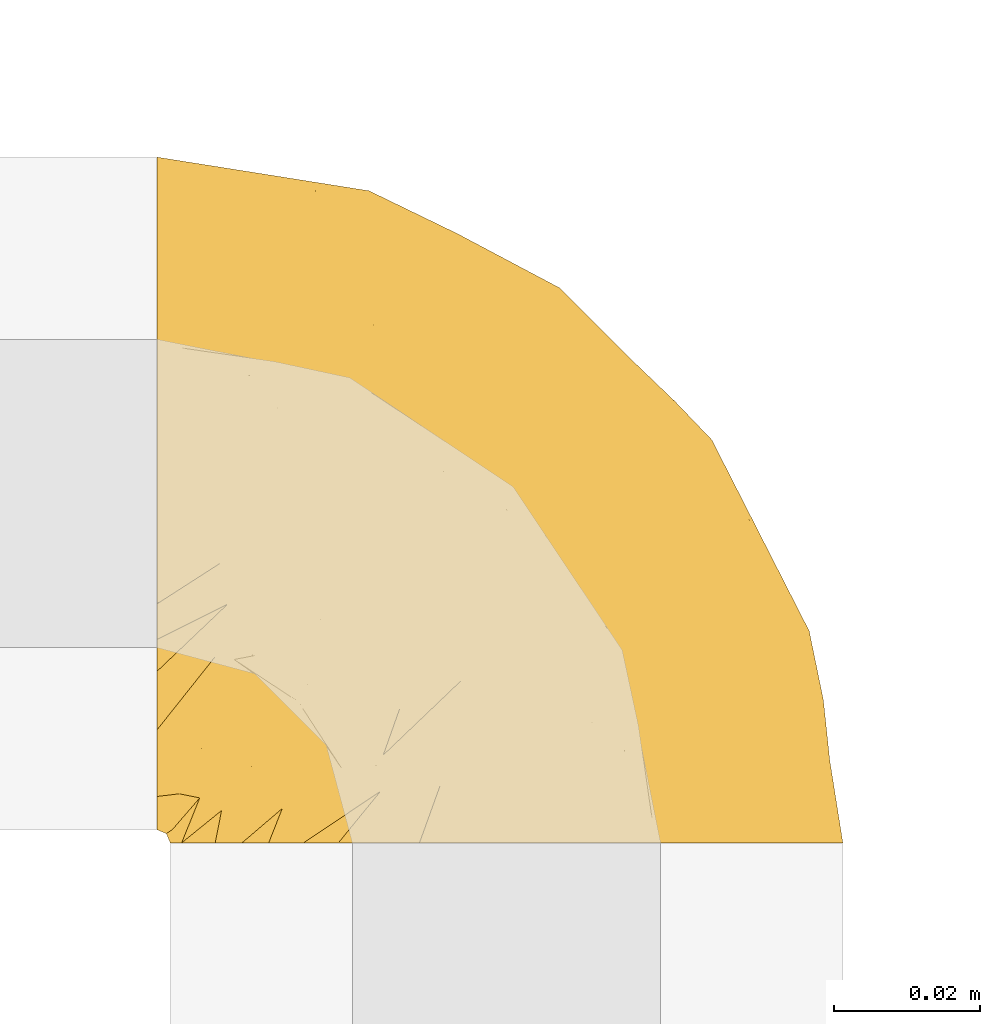
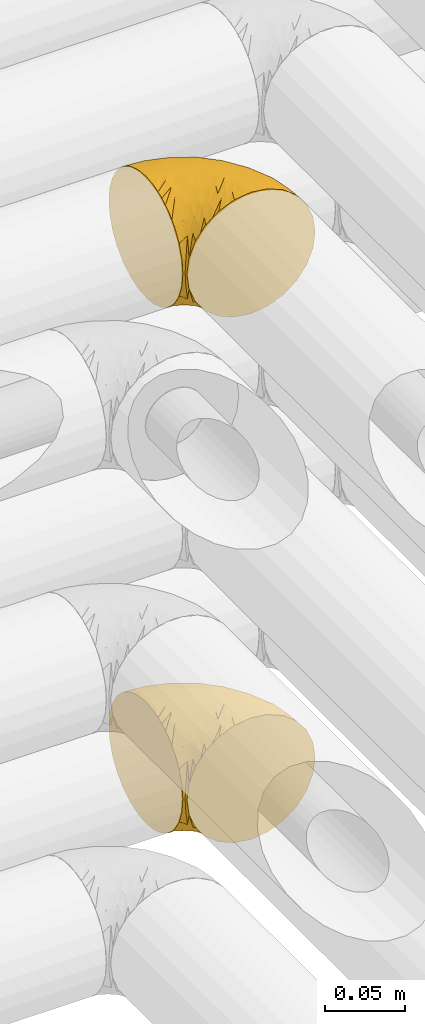
# One storey, part 181 of 827: 2 coverings.
"""IFC2X3 building model written with IfcOpenShell, lengths in millimetres."""

from ifc_helpers import new_model, entity, si_unit, converted_unit, derived_unit, direction, frame, origin, place, context, subcontext, project, spatial, faceted_brep, element, save


model = new_model("IFC2X3")

# Units and contexts
model_context = context("Model", 3, precision=0.01, world=origin(), true_north=direction((6.12303176911189e-17, 1.0)))
body_context = subcontext(model_context, "Body", "Model", "MODEL_VIEW")
ifc_project = project(units=[si_unit("LENGTHUNIT", "METRE", prefix="MILLI"), si_unit("AREAUNIT", "SQUARE_METRE"), si_unit("VOLUMEUNIT", "CUBIC_METRE"), converted_unit("PLANEANGLEUNIT", "DEGREE", entity("IfcRatioMeasure", 0.0174532925199433), si_unit("PLANEANGLEUNIT", "RADIAN"), dimensions=[0, 0, 0, 0, 0, 0, 0]), si_unit("MASSUNIT", "GRAM", prefix="KILO"), derived_unit("MASSDENSITYUNIT", [(si_unit("MASSUNIT", "GRAM", prefix="KILO"), 1), (si_unit("LENGTHUNIT", "METRE"), -3)]), derived_unit("MOMENTOFINERTIAUNIT", [(si_unit("LENGTHUNIT", "METRE"), 4)]), si_unit("TIMEUNIT", "SECOND"), si_unit("FREQUENCYUNIT", "HERTZ"), si_unit("THERMODYNAMICTEMPERATUREUNIT", "DEGREE_CELSIUS"), derived_unit("THERMALTRANSMITTANCEUNIT", [(si_unit("MASSUNIT", "GRAM", prefix="KILO"), 1), (si_unit("THERMODYNAMICTEMPERATUREUNIT", "KELVIN"), -1), (si_unit("TIMEUNIT", "SECOND"), -3)]), derived_unit("VOLUMETRICFLOWRATEUNIT", [(si_unit("LENGTHUNIT", "METRE"), 3), (si_unit("TIMEUNIT", "SECOND"), -1)]), derived_unit("MASSFLOWRATEUNIT", [(si_unit("MASSUNIT", "GRAM", prefix="KILO"), 1), (si_unit("TIMEUNIT", "SECOND"), -1)]), derived_unit("ROTATIONALFREQUENCYUNIT", [(si_unit("TIMEUNIT", "SECOND"), -1)]), si_unit("ELECTRICCURRENTUNIT", "AMPERE"), si_unit("ELECTRICVOLTAGEUNIT", "VOLT"), si_unit("POWERUNIT", "WATT"), si_unit("FORCEUNIT", "NEWTON", prefix="KILO"), si_unit("ILLUMINANCEUNIT", "LUX"), si_unit("LUMINOUSFLUXUNIT", "LUMEN"), si_unit("LUMINOUSINTENSITYUNIT", "CANDELA"), derived_unit("USERDEFINED", [(si_unit("MASSUNIT", "GRAM", prefix="KILO"), -1), (si_unit("LENGTHUNIT", "METRE"), -2), (si_unit("TIMEUNIT", "SECOND"), 3), (si_unit("LUMINOUSFLUXUNIT", "LUMEN"), 1)]), derived_unit("LINEARVELOCITYUNIT", [(si_unit("LENGTHUNIT", "METRE"), 1), (si_unit("TIMEUNIT", "SECOND"), -1)]), si_unit("PRESSUREUNIT", "PASCAL"), derived_unit("USERDEFINED", [(si_unit("LENGTHUNIT", "METRE"), -2), (si_unit("MASSUNIT", "GRAM", prefix="KILO"), 1), (si_unit("TIMEUNIT", "SECOND"), -2)]), derived_unit("LINEARFORCEUNIT", [(si_unit("MASSUNIT", "GRAM", prefix="KILO"), 1), (si_unit("LENGTHUNIT", "METRE"), 1), (si_unit("TIMEUNIT", "SECOND"), -2), (si_unit("LENGTHUNIT", "METRE"), -1)]), derived_unit("PLANARFORCEUNIT", [(si_unit("MASSUNIT", "GRAM", prefix="KILO"), 1), (si_unit("LENGTHUNIT", "METRE"), 1), (si_unit("TIMEUNIT", "SECOND"), -2), (si_unit("LENGTHUNIT", "METRE"), -2)])], contexts=[model_context])

# Site, building, storey
site_placement = place(None, origin())
site = spatial("IfcSite", under=ifc_project, at=site_placement, CompositionType="ELEMENT")
building_placement = place(site_placement, origin())
building = spatial("IfcBuilding", under=site, at=building_placement, CompositionType="ELEMENT")
storey_placement = place(building_placement, frame((0.0, 0.0, 28200.0)))
storey = spatial("IfcBuildingStorey", under=building, at=storey_placement, Name="08", CompositionType="ELEMENT", Elevation=28200.0)

# Coverings
covering_1_placement = place(storey_placement, frame((35420.44, 14180.41, 3352.2)))
element("IfcCovering", 1, at=covering_1_placement, inside=storey, Name=":ADSK_", ObjectType=":ADSK_", PredefinedType="INSULATION", context=body_context, shape_type="Brep", body=[
    faceted_brep([(1.6, 78.41, 83.91), (1.6, 85.72, 76.59), (1.6, 91.22, 67.83), (1.6, 94.64, 58.07), (1.6, 95.8, 47.8), (1.6, 94.64, 37.51), (1.6, 91.22, 27.74), (1.6, 85.71, 18.98), (1.6, 78.39, 11.67), (1.6, 69.63, 6.17), (1.6, 59.87, 2.75), (1.6, 49.6, 1.6), (1.6, 45.45, 2.06), (1.6, 42.38, 2.41), (1.6, 39.31, 2.75), (1.6, 34.43, 4.46), (1.6, 29.54, 6.17), (1.6, 25.16, 8.93), (1.6, 20.78, 11.68), (1.6, 17.13, 15.34), (1.6, 13.47, 19.0), (1.6, 7.97, 27.76), (1.6, 6.26, 32.64), (1.6, 4.55, 37.52), (1.6, 3.4, 47.8), (1.6, 4.55, 58.08), (1.6, 6.26, 62.96), (1.6, 7.97, 67.85), (1.6, 13.48, 76.61), (1.6, 17.14, 80.26), (1.6, 20.8, 83.92), (1.6, 25.18, 86.67), (1.6, 29.56, 89.42), (1.6, 34.44, 91.13), (1.6, 39.32, 92.84), (1.6, 42.39, 93.18), (1.6, 45.45, 93.53), (1.6, 49.6, 94.0), (1.6, 59.88, 92.84), (1.6, 69.65, 89.42), (3.4, 1.6, 47.8), (4.97, 1.6, 35.84), (9.58, 1.6, 24.7), (13.26, 1.6, 19.91), (16.93, 1.6, 15.13), (21.71, 1.6, 11.46), (26.5, 1.6, 7.78), (32.07, 1.6, 5.48), (37.64, 1.6, 3.17), (41.25, 1.6, 2.69), (43.34, 1.6, 2.42), (45.42, 1.6, 2.14), (49.6, 1.6, 1.6), (61.55, 1.6, 3.17), (72.7, 1.6, 7.78), (82.26, 1.6, 15.13), (89.61, 1.6, 24.7), (94.22, 1.6, 35.84), (95.8, 1.6, 47.8), (94.22, 1.6, 59.75), (89.61, 1.6, 70.9), (82.26, 1.6, 80.46), (72.7, 1.6, 87.81), (61.55, 1.6, 92.42), (49.6, 1.6, 94.0), (45.42, 1.6, 93.45), (41.25, 1.6, 92.9), (37.64, 1.6, 92.42), (32.07, 1.6, 90.11), (26.5, 1.6, 87.81), (21.71, 1.6, 84.13), (16.93, 1.6, 80.46), (13.26, 1.6, 75.68), (9.58, 1.6, 70.9), (4.97, 1.6, 59.75), (81.55, 36.81, 71.98), (90.4, 23.28, 63.6), (83.0, 45.8, 59.72), (91.18, 30.7, 47.8), (93.13, 21.2, 55.16), (94.0, 12.96, 47.8), (66.19, 66.19, 63.76), (70.92, 54.51, 72.22), (85.95, 17.98, 74.18), (49.74, 36.69, 92.52), (35.54, 35.54, 94.0), (38.14, 31.64, 94.0), (40.74, 27.75, 94.0), (43.34, 23.86, 94.0), (45.94, 19.96, 94.0), (77.59, 22.8, 82.14), (71.17, 42.67, 80.34), (65.81, 33.21, 87.52), (59.03, 59.45, 79.59), (45.85, 71.5, 78.25), (45.79, 62.66, 85.01), (41.42, 54.5, 90.25), (34.51, 47.57, 93.2), (56.04, 48.81, 87.23), (15.15, 74.98, 85.55), (56.51, 18.7, 93.0), (68.39, 15.75, 89.31), (23.33, 91.17, 61.31), (42.86, 85.28, 56.86), (39.42, 82.58, 68.34), (53.58, 75.78, 65.71), (59.17, 74.98, 56.99), (59.06, 67.27, 72.15), (22.63, 87.38, 70.34), (20.55, 82.04, 78.36), (12.96, 94.0, 47.8), (56.96, 77.8, 47.8), (67.38, 67.38, 47.8), (18.72, 56.2, 93.06), (5.33, 48.85, 94.0), (9.07, 48.11, 94.0), (11.79, 47.57, 94.0), (14.51, 47.03, 94.0), (17.24, 46.48, 94.0), (19.96, 45.94, 94.0), (21.03, 65.78, 89.88), (46.48, 17.24, 94.0), (47.03, 14.51, 94.0), (47.57, 11.79, 94.0), (48.11, 9.07, 94.0), (48.48, 7.2, 94.0), (48.85, 5.33, 94.0), (30.7, 91.18, 47.8), (23.86, 43.34, 94.0), (27.75, 40.74, 94.0), (31.64, 38.14, 94.0), (31.26, 72.73, 83.7), (77.8, 56.96, 47.8), (72.75, 62.23, 55.9), (43.83, 84.49, 47.8), (84.49, 43.83, 47.8), (14.58, 12.05, 81.75), (16.17, 18.95, 86.43), (10.82, 13.02, 79.8), (4.64, 8.34, 69.84), (7.71, 14.63, 79.5), (25.13, 11.09, 88.08), (32.66, 13.66, 91.6), (34.94, 20.08, 92.93), (36.76, 9.61, 92.43), (40.48, 9.48, 93.24), (39.25, 16.1, 93.36), (3.69, 3.42, 57.25), (13.99, 26.63, 89.41), (21.85, 33.72, 92.89), (17.93, 34.77, 92.66), (15.11, 6.75, 79.58), (21.14, 13.31, 86.51), (12.7, 21.11, 86.29), (7.21, 19.94, 83.91), (32.27, 8.67, 90.94), (25.68, 26.11, 91.94), (22.18, 29.3, 91.98), (18.79, 6.32, 82.79), (10.12, 39.92, 93.16), (9.47, 27.05, 88.76), (10.45, 6.04, 73.94), (11.29, 34.4, 91.89), (2.87, 2.87, 47.8), (31.16, 20.92, 92.22), (6.31, 27.43, 88.56), (25.62, 7.54, 87.72), (21.18, 18.45, 88.33), (28.81, 23.88, 92.18), (7.45, 7.77, 71.78), (21.14, 13.3, 9.09), (25.13, 11.09, 7.51), (18.79, 6.33, 12.8), (48.11, 9.07, 1.6), (48.85, 5.33, 1.6), (47.03, 14.51, 1.6), (47.57, 11.79, 1.6), (3.69, 3.42, 38.35), (7.44, 7.76, 23.84), (14.51, 47.03, 1.6), (11.79, 47.57, 1.6), (5.33, 48.85, 1.6), (9.07, 48.11, 1.6), (7.71, 14.62, 16.1), (9.47, 27.03, 6.84), (34.94, 20.08, 2.66), (31.16, 20.92, 3.37), (40.74, 27.75, 1.6), (38.14, 31.64, 1.6), (36.76, 9.61, 3.16), (40.48, 9.48, 2.35), (4.63, 8.33, 25.77), (15.11, 6.74, 16.02), (14.58, 12.04, 13.85), (43.34, 23.86, 1.6), (45.94, 19.96, 1.6), (39.25, 16.1, 2.23), (7.21, 19.93, 11.69), (12.69, 21.1, 9.31), (10.14, 39.92, 2.43), (21.81, 33.68, 2.71), (22.19, 29.28, 3.61), (14.0, 26.62, 6.18), (25.69, 26.08, 3.66), (16.17, 18.93, 9.17), (6.66, 27.87, 6.77), (17.92, 34.75, 2.93), (10.45, 6.04, 21.66), (31.64, 38.14, 1.6), (10.64, 12.79, 16.09), (11.31, 34.41, 3.7), (19.96, 45.94, 1.6), (23.86, 43.34, 1.6), (27.75, 40.74, 1.6), (32.66, 13.66, 3.99), (46.48, 17.24, 1.6), (32.27, 8.67, 4.65), (35.54, 35.54, 1.6), (28.77, 23.83, 3.43), (21.17, 18.43, 7.27), (23.36, 6.03, 9.46), (17.24, 46.48, 1.6), (47.58, 34.52, 2.4), (93.13, 21.2, 40.43), (77.44, 23.82, 13.57), (66.78, 41.32, 11.3), (71.68, 47.62, 18.65), (74.96, 52.66, 27.26), (81.55, 36.81, 23.61), (36.7, 49.75, 3.07), (56.9, 19.07, 2.69), (83.0, 45.8, 35.87), (90.4, 23.28, 31.99), (67.83, 21.35, 6.71), (85.95, 17.98, 21.41), (39.41, 82.57, 27.24), (23.33, 91.17, 34.26), (42.87, 85.27, 38.73), (53.92, 73.89, 26.97), (66.19, 66.19, 31.83), (64.12, 62.43, 23.4), (33.13, 63.53, 6.91), (23.1, 58.45, 3.4), (16.98, 67.16, 5.84), (55.72, 76.72, 35.73), (72.75, 62.22, 39.69), (23.77, 81.54, 17.6), (18.41, 74.8, 10.38), (43.7, 75.83, 20.6), (54.53, 41.45, 5.36), (17.73, 88.2, 24.84), (38.98, 71.6, 13.87), (50.28, 56.23, 9.06), (59.02, 59.44, 15.99)], [[[0, 1, 2, 3, 4, 5, 6, 7, 8, 9, 10, 11, 12, 13, 14, 15, 16, 17, 18, 19, 20, 21, 22, 23, 24, 25, 26, 27, 28, 29, 30, 31, 32, 33, 34, 35, 36, 37, 38, 39]], [[40, 41, 42, 43, 44, 45, 46, 47, 48, 49, 50, 51, 52, 53, 54, 55, 56, 57, 58, 59, 60, 61, 62, 63, 64, 65, 66, 67, 68, 69, 70, 71, 72, 73, 74]], [[75, 76, 77]], [[78, 79, 80]], [[77, 81, 82]], [[76, 75, 83]], [[84, 85, 86, 87, 88, 89]], [[90, 91, 92]], [[76, 60, 59]], [[93, 94, 95]], [[90, 62, 61]], [[83, 61, 60]], [[96, 97, 84]], [[98, 93, 95]], [[0, 39, 99]], [[100, 84, 89]], [[62, 101, 63]], [[2, 102, 3]], [[92, 84, 100]], [[103, 102, 104]], [[103, 105, 106]], [[93, 107, 94]], [[1, 108, 2]], [[92, 101, 90]], [[108, 1, 109]], [[102, 110, 3]], [[93, 82, 107]], [[102, 108, 104]], [[111, 106, 112]], [[109, 0, 99]], [[113, 37, 114, 115, 116, 117, 118, 119]], [[120, 38, 113]], [[100, 89, 121, 122, 123, 124, 125, 126, 64]], [[127, 102, 103]], [[97, 119, 128, 129, 130, 85]], [[99, 120, 131]], [[132, 133, 77]], [[59, 80, 79]], [[1, 0, 109]], [[98, 84, 92]], [[94, 109, 131]], [[120, 39, 38]], [[93, 91, 82]], [[104, 94, 105]], [[97, 113, 119]], [[95, 120, 96]], [[83, 90, 61]], [[91, 93, 98]], [[64, 63, 100]], [[100, 63, 101]], [[77, 76, 79]], [[133, 106, 81]], [[84, 97, 85]], [[113, 96, 120]], [[113, 97, 96]], [[37, 113, 38]], [[110, 102, 127]], [[110, 4, 3]], [[103, 111, 134, 127]], [[90, 75, 91]], [[82, 81, 107]], [[91, 75, 82]], [[77, 82, 75]], [[76, 83, 60]], [[90, 83, 75]], [[105, 107, 81]], [[94, 131, 95]], [[105, 94, 107]], [[109, 94, 104]], [[120, 95, 131]], [[98, 95, 96]], [[84, 98, 96]], [[98, 92, 91]], [[106, 105, 81]], [[103, 104, 105]], [[112, 106, 133]], [[103, 106, 111]], [[112, 133, 132]], [[81, 77, 133]], [[77, 78, 135, 132]], [[120, 99, 39]], [[109, 99, 131]], [[59, 58, 80]], [[59, 79, 76]], [[90, 101, 62]], [[100, 101, 92]], [[2, 108, 102]], [[109, 104, 108]], [[78, 77, 79]], [[136, 137, 138]], [[27, 139, 140]], [[141, 142, 143]], [[144, 145, 121]], [[146, 89, 88]], [[147, 139, 25]], [[148, 149, 150]], [[136, 151, 152]], [[147, 40, 74]], [[24, 147, 25]], [[140, 153, 154]], [[33, 116, 34]], [[73, 72, 151]], [[114, 37, 36, 35, 34, 116, 115]], [[146, 155, 144]], [[156, 85, 130]], [[157, 149, 148]], [[151, 158, 152]], [[117, 33, 159]], [[29, 154, 160]], [[161, 74, 73]], [[162, 128, 119]], [[66, 65, 64, 126, 125, 124, 123, 122, 67]], [[163, 147, 24]], [[27, 140, 28]], [[149, 129, 150]], [[139, 27, 26, 25]], [[68, 144, 69]], [[129, 128, 150]], [[164, 87, 86]], [[130, 129, 149]], [[122, 145, 67]], [[154, 153, 148]], [[162, 119, 159]], [[165, 30, 160]], [[150, 160, 148]], [[128, 162, 150]], [[30, 165, 31]], [[145, 144, 68]], [[89, 146, 144]], [[87, 164, 143]], [[166, 155, 142]], [[88, 87, 143]], [[162, 160, 150]], [[160, 30, 29]], [[154, 29, 28]], [[140, 154, 28]], [[160, 154, 148]], [[140, 137, 153]], [[157, 148, 153]], [[156, 130, 157]], [[153, 137, 157]], [[157, 137, 156]], [[167, 137, 136]], [[168, 85, 156]], [[152, 168, 167]], [[167, 168, 156]], [[164, 152, 141]], [[71, 158, 72]], [[152, 167, 136]], [[88, 142, 146]], [[144, 155, 69]], [[146, 142, 155]], [[70, 166, 71]], [[142, 141, 166]], [[70, 69, 155]], [[141, 158, 71]], [[161, 73, 151]], [[138, 137, 140]], [[161, 136, 169]], [[136, 161, 151]], [[74, 161, 169]], [[152, 158, 141]], [[151, 72, 158]], [[168, 152, 164]], [[137, 167, 156]], [[164, 86, 168]], [[85, 168, 86]], [[116, 33, 117]], [[130, 149, 157]], [[67, 145, 68]], [[121, 89, 144]], [[145, 122, 121]], [[40, 147, 163]], [[169, 147, 74]], [[159, 33, 32]], [[162, 159, 32]], [[159, 119, 118, 117]], [[139, 147, 169]], [[139, 169, 138]], [[162, 32, 31]], [[141, 143, 164]], [[88, 143, 142]], [[71, 166, 141]], [[155, 166, 70]], [[139, 138, 140]], [[169, 136, 138]], [[160, 162, 165]], [[162, 31, 165]], [[170, 171, 172]], [[173, 174, 52, 51, 50, 49, 48, 175, 176]], [[177, 178, 41]], [[179, 15, 180]], [[12, 11, 181, 182, 180, 14, 13]], [[183, 21, 20]], [[19, 18, 184]], [[185, 186, 187]], [[186, 188, 187]], [[43, 172, 44]], [[189, 190, 47]], [[23, 22, 21, 191]], [[170, 192, 193]], [[40, 163, 177]], [[194, 195, 196]], [[24, 23, 177]], [[197, 198, 183]], [[199, 15, 179]], [[47, 46, 189]], [[200, 201, 202]], [[201, 203, 204]], [[205, 206, 184]], [[207, 41, 178]], [[16, 15, 199]], [[14, 180, 15]], [[202, 201, 198]], [[208, 201, 200]], [[163, 24, 177]], [[48, 47, 190]], [[196, 195, 189]], [[197, 184, 202]], [[204, 193, 209]], [[210, 211, 212]], [[206, 212, 213]], [[205, 17, 210]], [[184, 206, 202]], [[210, 212, 206]], [[185, 194, 214]], [[189, 215, 190]], [[216, 45, 214]], [[186, 171, 170]], [[189, 216, 196]], [[197, 20, 19]], [[194, 185, 187]], [[197, 183, 20]], [[184, 197, 19]], [[197, 202, 198]], [[206, 200, 202]], [[204, 183, 198]], [[201, 208, 203]], [[203, 208, 217]], [[204, 198, 201]], [[217, 188, 218]], [[193, 219, 170]], [[171, 186, 185]], [[170, 218, 186]], [[170, 219, 218]], [[42, 207, 192]], [[171, 220, 172]], [[216, 189, 46]], [[214, 194, 196]], [[44, 220, 45]], [[214, 196, 216]], [[216, 46, 45]], [[214, 45, 220]], [[192, 43, 42]], [[204, 203, 219]], [[207, 193, 192]], [[209, 193, 178]], [[41, 207, 42]], [[193, 207, 178]], [[43, 192, 172]], [[170, 172, 192]], [[204, 219, 193]], [[219, 203, 218]], [[217, 218, 203]], [[188, 186, 218]], [[206, 213, 200]], [[208, 200, 213]], [[199, 210, 16]], [[215, 189, 195]], [[215, 175, 190]], [[175, 48, 190]], [[199, 179, 221, 211]], [[210, 199, 211]], [[23, 191, 177]], [[40, 177, 41]], [[178, 177, 191]], [[21, 183, 191]], [[209, 191, 183]], [[205, 18, 17]], [[17, 16, 210]], [[171, 185, 214]], [[172, 220, 44]], [[214, 220, 171]], [[191, 209, 178]], [[204, 209, 183]], [[206, 205, 210]], [[18, 205, 184]], [[222, 195, 194, 187, 188, 217]], [[57, 223, 80]], [[224, 225, 226]], [[226, 227, 228]], [[229, 217, 208, 213, 212, 211]], [[230, 52, 174, 173, 176, 175, 215, 195]], [[231, 232, 228]], [[231, 78, 223]], [[223, 57, 232]], [[224, 233, 225]], [[233, 54, 53]], [[234, 232, 56]], [[56, 55, 234]], [[234, 224, 228]], [[235, 236, 237]], [[224, 55, 54]], [[238, 239, 240]], [[52, 230, 53]], [[241, 242, 243]], [[239, 244, 245]], [[11, 10, 242]], [[236, 6, 5]], [[7, 246, 8]], [[8, 247, 9]], [[238, 248, 235]], [[222, 229, 249]], [[242, 211, 221, 179, 180, 182, 181, 11]], [[233, 53, 230]], [[111, 112, 244]], [[250, 6, 236]], [[247, 251, 241]], [[6, 250, 7]], [[127, 236, 110]], [[249, 229, 252]], [[247, 8, 246]], [[235, 246, 250]], [[236, 5, 110]], [[235, 244, 238]], [[237, 236, 127]], [[243, 9, 247]], [[252, 229, 241]], [[56, 232, 57]], [[222, 230, 195]], [[225, 249, 252]], [[249, 233, 230]], [[54, 233, 224]], [[231, 228, 227]], [[245, 132, 231]], [[249, 225, 233]], [[226, 225, 253]], [[235, 250, 236]], [[246, 7, 250]], [[251, 247, 246]], [[243, 247, 241]], [[248, 246, 235]], [[252, 251, 253]], [[229, 222, 217]], [[230, 222, 249]], [[5, 4, 110]], [[237, 127, 134, 111]], [[238, 244, 239]], [[224, 234, 55]], [[232, 234, 228]], [[242, 241, 229]], [[10, 9, 243]], [[211, 242, 229]], [[10, 243, 242]], [[80, 223, 78]], [[80, 58, 57]], [[231, 223, 232]], [[227, 240, 239]], [[224, 226, 228]], [[240, 226, 253]], [[227, 239, 245]], [[226, 240, 227]], [[251, 248, 253]], [[240, 253, 248]], [[244, 235, 237]], [[237, 111, 244]], [[132, 245, 112]], [[112, 245, 244]], [[135, 78, 231, 132]], [[227, 245, 231]], [[248, 238, 240]], [[246, 248, 251]], [[251, 252, 241]], [[225, 252, 253]]]),
])
covering_2_placement = place(storey_placement, frame((35420.44, 14180.41, 2952.2)))
element("IfcCovering", 2, at=covering_2_placement, inside=storey, Name=":ADSK_", ObjectType=":ADSK_", PredefinedType="INSULATION", context=body_context, shape_type="Brep", body=[
    faceted_brep([(1.6, 59.88, 92.84), (1.6, 69.65, 89.42), (1.6, 78.41, 83.91), (1.6, 85.72, 76.59), (1.6, 91.22, 67.83), (1.6, 94.64, 58.07), (1.6, 95.8, 47.8), (1.6, 94.64, 37.51), (1.6, 91.22, 27.74), (1.6, 85.71, 18.98), (1.6, 78.39, 11.67), (1.6, 69.63, 6.17), (1.6, 59.87, 2.75), (1.6, 49.6, 1.6), (1.6, 45.45, 2.06), (1.6, 42.38, 2.41), (1.6, 39.31, 2.75), (1.6, 34.43, 4.46), (1.6, 29.54, 6.17), (1.6, 25.16, 8.93), (1.6, 20.78, 11.68), (1.6, 17.13, 15.34), (1.6, 13.47, 19.0), (1.6, 7.97, 27.76), (1.6, 6.26, 32.64), (1.6, 4.55, 37.52), (1.6, 3.4, 47.8), (1.6, 4.55, 58.08), (1.6, 6.26, 62.96), (1.6, 7.97, 67.85), (1.6, 13.48, 76.61), (1.6, 17.14, 80.26), (1.6, 20.8, 83.92), (1.6, 25.18, 86.67), (1.6, 29.56, 89.42), (1.6, 34.44, 91.13), (1.6, 39.32, 92.84), (1.6, 42.39, 93.18), (1.6, 45.45, 93.53), (1.6, 49.6, 94.0), (3.4, 1.6, 47.8), (4.97, 1.6, 35.84), (9.58, 1.6, 24.7), (13.26, 1.6, 19.91), (16.93, 1.6, 15.13), (21.71, 1.6, 11.46), (26.5, 1.6, 7.78), (32.07, 1.6, 5.48), (37.64, 1.6, 3.17), (41.25, 1.6, 2.69), (43.34, 1.6, 2.42), (45.42, 1.6, 2.14), (49.6, 1.6, 1.6), (61.55, 1.6, 3.17), (72.7, 1.6, 7.78), (82.26, 1.6, 15.13), (89.61, 1.6, 24.7), (94.22, 1.6, 35.84), (95.8, 1.6, 47.8), (94.22, 1.6, 59.75), (89.61, 1.6, 70.9), (82.26, 1.6, 80.46), (72.7, 1.6, 87.81), (61.55, 1.6, 92.42), (49.6, 1.6, 94.0), (45.42, 1.6, 93.45), (41.25, 1.6, 92.9), (37.64, 1.6, 92.42), (32.07, 1.6, 90.11), (26.5, 1.6, 87.81), (21.71, 1.6, 84.13), (16.93, 1.6, 80.46), (13.26, 1.6, 75.68), (9.58, 1.6, 70.9), (4.97, 1.6, 59.75), (81.55, 36.81, 71.98), (90.4, 23.28, 63.6), (83.0, 45.8, 59.72), (91.18, 30.7, 47.8), (93.13, 21.2, 55.16), (94.0, 12.96, 47.8), (66.19, 66.19, 63.76), (70.92, 54.51, 72.22), (85.95, 17.98, 74.18), (49.74, 36.69, 92.52), (35.54, 35.54, 94.0), (38.14, 31.64, 94.0), (40.74, 27.75, 94.0), (43.34, 23.86, 94.0), (45.94, 19.96, 94.0), (77.59, 22.8, 82.14), (71.17, 42.67, 80.34), (65.81, 33.21, 87.52), (59.03, 59.45, 79.59), (45.85, 71.5, 78.25), (45.79, 62.66, 85.01), (41.42, 54.5, 90.25), (34.51, 47.57, 93.2), (56.04, 48.81, 87.23), (15.15, 74.98, 85.55), (56.51, 18.7, 93.0), (68.39, 15.75, 89.31), (23.33, 91.17, 61.31), (42.86, 85.28, 56.86), (39.42, 82.58, 68.34), (53.58, 75.78, 65.71), (59.17, 74.98, 56.99), (59.06, 67.27, 72.15), (22.63, 87.38, 70.34), (20.55, 82.04, 78.36), (12.96, 94.0, 47.8), (56.96, 77.8, 47.8), (67.38, 67.38, 47.8), (18.72, 56.2, 93.06), (5.33, 48.85, 94.0), (9.07, 48.11, 94.0), (11.79, 47.57, 94.0), (14.51, 47.03, 94.0), (17.24, 46.48, 94.0), (19.96, 45.94, 94.0), (21.03, 65.78, 89.88), (46.48, 17.24, 94.0), (47.03, 14.51, 94.0), (47.57, 11.79, 94.0), (48.11, 9.07, 94.0), (48.48, 7.2, 94.0), (48.85, 5.33, 94.0), (30.7, 91.18, 47.8), (23.86, 43.34, 94.0), (27.75, 40.74, 94.0), (31.64, 38.14, 94.0), (31.26, 72.73, 83.7), (77.8, 56.96, 47.8), (72.75, 62.23, 55.9), (43.83, 84.49, 47.8), (84.49, 43.83, 47.8), (14.58, 12.05, 81.75), (16.17, 18.95, 86.43), (10.82, 13.02, 79.8), (4.64, 8.34, 69.84), (7.71, 14.63, 79.5), (25.13, 11.09, 88.08), (32.66, 13.66, 91.6), (34.94, 20.08, 92.93), (36.76, 9.61, 92.43), (40.48, 9.48, 93.24), (39.25, 16.1, 93.36), (3.69, 3.42, 57.25), (13.99, 26.63, 89.41), (21.85, 33.72, 92.89), (17.93, 34.77, 92.66), (15.11, 6.75, 79.58), (21.14, 13.31, 86.51), (12.7, 21.11, 86.29), (7.21, 19.94, 83.91), (32.27, 8.67, 90.94), (25.68, 26.11, 91.94), (22.18, 29.3, 91.98), (18.79, 6.32, 82.79), (10.12, 39.92, 93.16), (9.47, 27.05, 88.76), (10.45, 6.04, 73.94), (11.29, 34.4, 91.89), (2.87, 2.87, 47.8), (31.16, 20.92, 92.22), (6.31, 27.43, 88.56), (25.62, 7.54, 87.72), (21.18, 18.45, 88.33), (28.81, 23.88, 92.18), (7.45, 7.77, 71.78), (21.14, 13.3, 9.09), (25.13, 11.09, 7.51), (18.79, 6.33, 12.8), (48.11, 9.07, 1.6), (48.85, 5.33, 1.6), (47.03, 14.51, 1.6), (47.57, 11.79, 1.6), (3.69, 3.42, 38.35), (7.44, 7.76, 23.84), (14.51, 47.03, 1.6), (11.79, 47.57, 1.6), (5.33, 48.85, 1.6), (9.07, 48.11, 1.6), (7.71, 14.62, 16.1), (9.47, 27.03, 6.84), (34.94, 20.08, 2.66), (31.16, 20.92, 3.37), (40.74, 27.75, 1.6), (38.14, 31.64, 1.6), (36.76, 9.61, 3.16), (40.48, 9.48, 2.35), (4.63, 8.33, 25.77), (15.11, 6.74, 16.02), (14.58, 12.04, 13.85), (43.34, 23.86, 1.6), (45.94, 19.96, 1.6), (39.25, 16.1, 2.23), (7.21, 19.93, 11.69), (12.69, 21.1, 9.31), (10.14, 39.92, 2.43), (21.81, 33.68, 2.71), (22.19, 29.28, 3.61), (14.0, 26.62, 6.18), (25.69, 26.08, 3.66), (16.17, 18.93, 9.17), (6.66, 27.87, 6.77), (17.92, 34.75, 2.93), (10.45, 6.04, 21.66), (31.64, 38.14, 1.6), (10.64, 12.79, 16.09), (11.31, 34.41, 3.7), (19.96, 45.94, 1.6), (23.86, 43.34, 1.6), (27.75, 40.74, 1.6), (32.66, 13.66, 3.99), (46.48, 17.24, 1.6), (32.27, 8.67, 4.65), (35.54, 35.54, 1.6), (28.77, 23.83, 3.43), (21.17, 18.43, 7.27), (23.36, 6.03, 9.46), (17.24, 46.48, 1.6), (47.58, 34.52, 2.4), (93.13, 21.2, 40.43), (77.44, 23.82, 13.57), (66.78, 41.32, 11.3), (71.68, 47.62, 18.65), (74.96, 52.66, 27.26), (81.55, 36.81, 23.61), (36.7, 49.75, 3.07), (56.9, 19.07, 2.69), (83.0, 45.8, 35.87), (90.4, 23.28, 31.99), (67.83, 21.35, 6.71), (85.95, 17.98, 21.41), (39.41, 82.57, 27.24), (23.33, 91.17, 34.26), (42.87, 85.27, 38.73), (53.92, 73.89, 26.97), (66.19, 66.19, 31.83), (64.12, 62.43, 23.4), (33.13, 63.53, 6.91), (23.1, 58.45, 3.4), (16.98, 67.16, 5.84), (55.72, 76.72, 35.73), (72.75, 62.22, 39.69), (23.77, 81.54, 17.6), (18.41, 74.8, 10.38), (43.7, 75.83, 20.6), (54.53, 41.45, 5.36), (17.73, 88.2, 24.84), (38.98, 71.6, 13.87), (50.28, 56.23, 9.06), (59.02, 59.44, 15.99)], [[[0, 1, 2, 3, 4, 5, 6, 7, 8, 9, 10, 11, 12, 13, 14, 15, 16, 17, 18, 19, 20, 21, 22, 23, 24, 25, 26, 27, 28, 29, 30, 31, 32, 33, 34, 35, 36, 37, 38, 39]], [[40, 41, 42, 43, 44, 45, 46, 47, 48, 49, 50, 51, 52, 53, 54, 55, 56, 57, 58, 59, 60, 61, 62, 63, 64, 65, 66, 67, 68, 69, 70, 71, 72, 73, 74]], [[75, 76, 77]], [[78, 79, 80]], [[77, 81, 82]], [[76, 75, 83]], [[84, 85, 86, 87, 88, 89]], [[90, 91, 92]], [[76, 60, 59]], [[93, 94, 95]], [[90, 62, 61]], [[83, 61, 60]], [[96, 97, 84]], [[98, 93, 95]], [[2, 1, 99]], [[100, 84, 89]], [[62, 101, 63]], [[4, 102, 5]], [[92, 84, 100]], [[103, 102, 104]], [[103, 105, 106]], [[93, 107, 94]], [[3, 108, 4]], [[92, 101, 90]], [[108, 3, 109]], [[102, 110, 5]], [[93, 82, 107]], [[102, 108, 104]], [[111, 106, 112]], [[109, 2, 99]], [[113, 39, 114, 115, 116, 117, 118, 119]], [[120, 0, 113]], [[100, 89, 121, 122, 123, 124, 125, 126, 64]], [[127, 102, 103]], [[97, 119, 128, 129, 130, 85]], [[99, 120, 131]], [[132, 133, 77]], [[59, 80, 79]], [[3, 2, 109]], [[98, 84, 92]], [[94, 109, 131]], [[120, 1, 0]], [[93, 91, 82]], [[104, 94, 105]], [[97, 113, 119]], [[95, 120, 96]], [[83, 90, 61]], [[91, 93, 98]], [[64, 63, 100]], [[100, 63, 101]], [[77, 76, 79]], [[133, 106, 81]], [[84, 97, 85]], [[113, 96, 120]], [[113, 97, 96]], [[39, 113, 0]], [[110, 102, 127]], [[110, 6, 5]], [[103, 111, 134, 127]], [[90, 75, 91]], [[82, 81, 107]], [[91, 75, 82]], [[77, 82, 75]], [[76, 83, 60]], [[90, 83, 75]], [[105, 107, 81]], [[94, 131, 95]], [[105, 94, 107]], [[109, 94, 104]], [[120, 95, 131]], [[98, 95, 96]], [[84, 98, 96]], [[98, 92, 91]], [[106, 105, 81]], [[103, 104, 105]], [[112, 106, 133]], [[103, 106, 111]], [[112, 133, 132]], [[81, 77, 133]], [[77, 78, 135, 132]], [[120, 99, 1]], [[109, 99, 131]], [[59, 58, 80]], [[59, 79, 76]], [[90, 101, 62]], [[100, 101, 92]], [[4, 108, 102]], [[109, 104, 108]], [[78, 77, 79]], [[136, 137, 138]], [[29, 139, 140]], [[141, 142, 143]], [[144, 145, 121]], [[146, 89, 88]], [[147, 139, 27]], [[148, 149, 150]], [[136, 151, 152]], [[147, 40, 74]], [[26, 147, 27]], [[140, 153, 154]], [[35, 116, 36]], [[73, 72, 151]], [[114, 39, 38, 37, 36, 116, 115]], [[146, 155, 144]], [[156, 85, 130]], [[157, 149, 148]], [[151, 158, 152]], [[117, 35, 159]], [[31, 154, 160]], [[161, 74, 73]], [[162, 128, 119]], [[66, 65, 64, 126, 125, 124, 123, 122, 67]], [[163, 147, 26]], [[29, 140, 30]], [[149, 129, 150]], [[139, 29, 28, 27]], [[68, 144, 69]], [[129, 128, 150]], [[164, 87, 86]], [[130, 129, 149]], [[122, 145, 67]], [[154, 153, 148]], [[162, 119, 159]], [[165, 32, 160]], [[150, 160, 148]], [[128, 162, 150]], [[32, 165, 33]], [[145, 144, 68]], [[89, 146, 144]], [[87, 164, 143]], [[166, 155, 142]], [[88, 87, 143]], [[162, 160, 150]], [[160, 32, 31]], [[154, 31, 30]], [[140, 154, 30]], [[160, 154, 148]], [[140, 137, 153]], [[157, 148, 153]], [[156, 130, 157]], [[153, 137, 157]], [[157, 137, 156]], [[167, 137, 136]], [[168, 85, 156]], [[152, 168, 167]], [[167, 168, 156]], [[164, 152, 141]], [[71, 158, 72]], [[152, 167, 136]], [[88, 142, 146]], [[144, 155, 69]], [[146, 142, 155]], [[70, 166, 71]], [[142, 141, 166]], [[70, 69, 155]], [[141, 158, 71]], [[161, 73, 151]], [[138, 137, 140]], [[161, 136, 169]], [[136, 161, 151]], [[74, 161, 169]], [[152, 158, 141]], [[151, 72, 158]], [[168, 152, 164]], [[137, 167, 156]], [[164, 86, 168]], [[85, 168, 86]], [[116, 35, 117]], [[130, 149, 157]], [[67, 145, 68]], [[121, 89, 144]], [[145, 122, 121]], [[40, 147, 163]], [[169, 147, 74]], [[159, 35, 34]], [[162, 159, 34]], [[159, 119, 118, 117]], [[139, 147, 169]], [[139, 169, 138]], [[162, 34, 33]], [[141, 143, 164]], [[88, 143, 142]], [[71, 166, 141]], [[155, 166, 70]], [[139, 138, 140]], [[169, 136, 138]], [[160, 162, 165]], [[162, 33, 165]], [[170, 171, 172]], [[173, 174, 52, 51, 50, 49, 48, 175, 176]], [[177, 178, 41]], [[179, 17, 180]], [[14, 13, 181, 182, 180, 16, 15]], [[183, 23, 22]], [[21, 20, 184]], [[185, 186, 187]], [[186, 188, 187]], [[43, 172, 44]], [[189, 190, 47]], [[25, 24, 23, 191]], [[170, 192, 193]], [[40, 163, 177]], [[194, 195, 196]], [[26, 25, 177]], [[197, 198, 183]], [[199, 17, 179]], [[47, 46, 189]], [[200, 201, 202]], [[201, 203, 204]], [[205, 206, 184]], [[207, 41, 178]], [[18, 17, 199]], [[16, 180, 17]], [[202, 201, 198]], [[208, 201, 200]], [[163, 26, 177]], [[48, 47, 190]], [[196, 195, 189]], [[197, 184, 202]], [[204, 193, 209]], [[210, 211, 212]], [[206, 212, 213]], [[205, 19, 210]], [[184, 206, 202]], [[210, 212, 206]], [[185, 194, 214]], [[189, 215, 190]], [[216, 45, 214]], [[186, 171, 170]], [[189, 216, 196]], [[197, 22, 21]], [[194, 185, 187]], [[197, 183, 22]], [[184, 197, 21]], [[197, 202, 198]], [[206, 200, 202]], [[204, 183, 198]], [[201, 208, 203]], [[203, 208, 217]], [[204, 198, 201]], [[217, 188, 218]], [[193, 219, 170]], [[171, 186, 185]], [[170, 218, 186]], [[170, 219, 218]], [[42, 207, 192]], [[171, 220, 172]], [[216, 189, 46]], [[214, 194, 196]], [[44, 220, 45]], [[214, 196, 216]], [[216, 46, 45]], [[214, 45, 220]], [[192, 43, 42]], [[204, 203, 219]], [[207, 193, 192]], [[209, 193, 178]], [[41, 207, 42]], [[193, 207, 178]], [[43, 192, 172]], [[170, 172, 192]], [[204, 219, 193]], [[219, 203, 218]], [[217, 218, 203]], [[188, 186, 218]], [[206, 213, 200]], [[208, 200, 213]], [[199, 210, 18]], [[215, 189, 195]], [[215, 175, 190]], [[175, 48, 190]], [[199, 179, 221, 211]], [[210, 199, 211]], [[25, 191, 177]], [[40, 177, 41]], [[178, 177, 191]], [[23, 183, 191]], [[209, 191, 183]], [[205, 20, 19]], [[19, 18, 210]], [[171, 185, 214]], [[172, 220, 44]], [[214, 220, 171]], [[191, 209, 178]], [[204, 209, 183]], [[206, 205, 210]], [[20, 205, 184]], [[222, 195, 194, 187, 188, 217]], [[57, 223, 80]], [[224, 225, 226]], [[226, 227, 228]], [[229, 217, 208, 213, 212, 211]], [[230, 52, 174, 173, 176, 175, 215, 195]], [[231, 232, 228]], [[231, 78, 223]], [[223, 57, 232]], [[224, 233, 225]], [[233, 54, 53]], [[234, 232, 56]], [[56, 55, 234]], [[234, 224, 228]], [[235, 236, 237]], [[224, 55, 54]], [[238, 239, 240]], [[52, 230, 53]], [[241, 242, 243]], [[239, 244, 245]], [[13, 12, 242]], [[236, 8, 7]], [[9, 246, 10]], [[10, 247, 11]], [[238, 248, 235]], [[222, 229, 249]], [[242, 211, 221, 179, 180, 182, 181, 13]], [[233, 53, 230]], [[111, 112, 244]], [[250, 8, 236]], [[247, 251, 241]], [[8, 250, 9]], [[127, 236, 110]], [[249, 229, 252]], [[247, 10, 246]], [[235, 246, 250]], [[236, 7, 110]], [[235, 244, 238]], [[237, 236, 127]], [[243, 11, 247]], [[252, 229, 241]], [[56, 232, 57]], [[222, 230, 195]], [[225, 249, 252]], [[249, 233, 230]], [[54, 233, 224]], [[231, 228, 227]], [[245, 132, 231]], [[249, 225, 233]], [[226, 225, 253]], [[235, 250, 236]], [[246, 9, 250]], [[251, 247, 246]], [[243, 247, 241]], [[248, 246, 235]], [[252, 251, 253]], [[229, 222, 217]], [[230, 222, 249]], [[7, 6, 110]], [[237, 127, 134, 111]], [[238, 244, 239]], [[224, 234, 55]], [[232, 234, 228]], [[242, 241, 229]], [[12, 11, 243]], [[211, 242, 229]], [[12, 243, 242]], [[80, 223, 78]], [[80, 58, 57]], [[231, 223, 232]], [[227, 240, 239]], [[224, 226, 228]], [[240, 226, 253]], [[227, 239, 245]], [[226, 240, 227]], [[251, 248, 253]], [[240, 253, 248]], [[244, 235, 237]], [[237, 111, 244]], [[132, 245, 112]], [[112, 245, 244]], [[135, 78, 231, 132]], [[227, 245, 231]], [[248, 238, 240]], [[246, 248, 251]], [[251, 252, 241]], [[225, 252, 253]]]),
])

save(model, "model.ifc")
